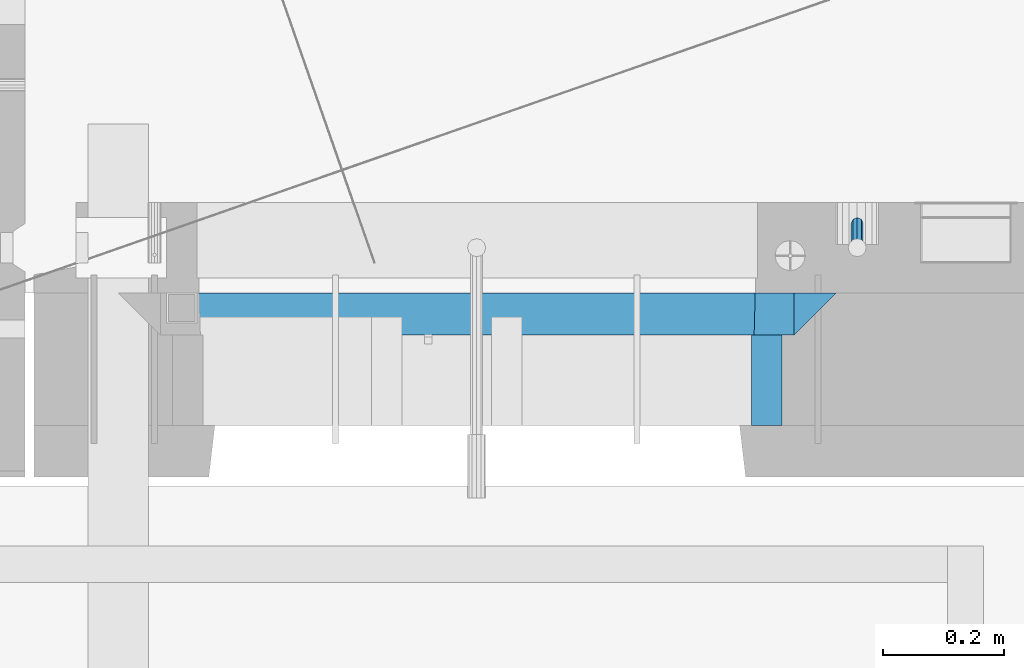
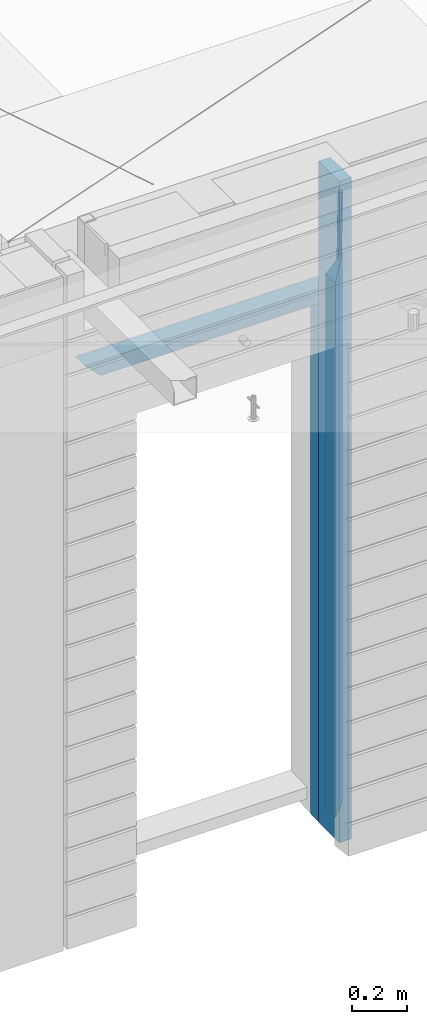
# One storey, part 89 of 341: 5 beams, 1 element without a shape of its own.
"""IFC2X3 building model written with IfcOpenShell, lengths in millimetres."""

import ifcopenshell
import ifcopenshell.guid

model = None  # the IFC model being written
_history = None  # IfcOwnerHistory: only IFC2X3 demands one
_inside = {}  # id of a spatial element -> (the spatial element, [elements in it])
_under = {}  # id of a project, library or spatial element -> (it, [spatial elements below it])
_declared = {}  # id of a project -> (the project, [libraries it declares])
_typed = {}  # id of a type object -> (the type object, [elements of that type])
_made_of = {}  # id of a material, layer set ... -> (it, [elements and type objects made of it])


def new_model(schema):
    """Start an empty IFC model of exactly this schema.

    Asked for "IFC4X3", IfcOpenShell would pick the latest addendum, in which some entities
    have other attributes; the version numbers below select the first issue.
    IFC2X3 requires an IfcOwnerHistory on every rooted entity: one is made here for all.
    """
    global model, _history
    if schema == "IFC4X3":
        model = ifcopenshell.file(schema_version=(4, 3, 0, 0))
    else:
        model = ifcopenshell.file(schema=schema)
    _inside.clear()
    _under.clear()
    _declared.clear()
    _typed.clear()
    _made_of.clear()
    _history = None
    if model.schema == "IFC2X3":
        org = make("IfcOrganization", Name="unknown")
        user = make(
            "IfcPersonAndOrganization",
            ThePerson=make("IfcPerson", FamilyName="unknown"),
            TheOrganization=org,
        )
        app = make(
            "IfcApplication",
            ApplicationDeveloper=org,
            Version="unknown",
            ApplicationFullName="unknown",
            ApplicationIdentifier="unknown",
        )
        _history = make(
            "IfcOwnerHistory",
            OwningUser=user,
            OwningApplication=app,
            ChangeAction="ADDED",
            CreationDate=0,
        )
    return model


def make(cls, **values):
    """One entity of the class cls with the attributes given. An attribute that is None is left unset."""
    return model.create_entity(
        cls, **{name: value for name, value in values.items() if value is not None}
    )


def rooted(cls, **values):
    """An entity with a GlobalId (a new one), such as an element, a storey or a relation."""
    return make(cls, GlobalId=ifcopenshell.guid.new(), OwnerHistory=_history, **values)


def si_unit(unit_type, name, prefix=None):
    """IfcSIUnit, for example si_unit("LENGTHUNIT", "METRE", prefix="MILLI")."""
    return make("IfcSIUnit", UnitType=unit_type, Prefix=prefix, Name=name)


def assignment(units):
    """IfcUnitAssignment: the units of a project."""
    return None if units is None else make("IfcUnitAssignment", Units=units)


def point(xyz):
    """IfcCartesianPoint."""
    return None if xyz is None else make("IfcCartesianPoint", Coordinates=xyz)


def direction(xyz):
    """IfcDirection."""
    return None if xyz is None else make("IfcDirection", DirectionRatios=xyz)


def frame(location, z_axis=None, x_axis=None):
    """IfcAxis2Placement3D, a coordinate frame: its origin and axes. An axis left out is left unset."""
    return make(
        "IfcAxis2Placement3D",
        Location=point(location),
        Axis=direction(z_axis),
        RefDirection=direction(x_axis),
    )


def origin_with_axes():
    """The frame at (0, 0, 0) with the z axis (0, 0, 1) and the x axis (1, 0, 0) written out."""
    return frame((0.0, 0.0, 0.0), z_axis=(0.0, 0.0, 1.0), x_axis=(1.0, 0.0, 0.0))


def place(relative_to, where):
    """IfcLocalPlacement: puts the frame where relative to a parent placement (None: the world)."""
    return make(
        "IfcLocalPlacement", PlacementRelTo=relative_to, RelativePlacement=where
    )


def context(
    kind, dimensions, precision=None, world=None, true_north=None, identifier=None
):
    """IfcGeometricRepresentationContext, for example the 3D "Model" context."""
    return make(
        "IfcGeometricRepresentationContext",
        ContextIdentifier=identifier,
        ContextType=kind,
        CoordinateSpaceDimension=dimensions,
        Precision=precision,
        WorldCoordinateSystem=world,
        TrueNorth=true_north,
    )


def subcontext(parent, identifier, kind, view, scale=None):
    """IfcGeometricRepresentationSubContext, for example "Body" below "Model"."""
    return make(
        "IfcGeometricRepresentationSubContext",
        ContextIdentifier=identifier,
        ContextType=kind,
        ParentContext=parent,
        TargetScale=scale,
        TargetView=view,
    )


def project(units=None, contexts=None):
    """IfcProject with its units and contexts."""
    return rooted(
        "IfcProject",
        Name="project",
        RepresentationContexts=contexts,
        UnitsInContext=assignment(units),
    )


def spatial(cls, under=None, at=None, **own):
    """A site, building, storey or space (cls), placed at a placement, below another one or the project."""
    s = rooted(cls, ObjectPlacement=at, **own)
    if under is not None:
        _under.setdefault(under.id(), (under, []))[1].append(s)
    return s


def faces_of(points, faces, orient=None, outer=None):
    """IfcFace entities. A face is a list of loops; a loop is a list of indices into points, from 0.

    orient and outer hold one flag for each loop. By default every Orientation is true, the
    first loop of a face is its IfcFaceOuterBound and the others are IfcFaceBound.
    """
    made = []
    for i, loops in enumerate(faces):
        bounds = []
        for j, loop in enumerate(loops):
            is_outer = j == 0 if outer is None else outer[i][j]
            bounds.append(
                make(
                    "IfcFaceOuterBound" if is_outer else "IfcFaceBound",
                    Bound=make("IfcPolyLoop", Polygon=[points[k] for k in loop]),
                    Orientation=True if orient is None else orient[i][j],
                )
            )
        made.append(make("IfcFace", Bounds=bounds))
    return made


def faceted_brep(points, faces, orient=None, outer=None, voids=None):
    """IfcFacetedBrep: a solid bounded by flat faces; with voids (closed shells), ...WithVoids."""
    shared = [point(p) for p in points]
    hull = make("IfcClosedShell", CfsFaces=faces_of(shared, faces, orient, outer))
    if voids is None:
        return make("IfcFacetedBrep", Outer=hull)
    return make(
        "IfcFacetedBrepWithVoids",
        Outer=hull,
        Voids=[
            make(cls, CfsFaces=faces_of(shared, fs, o, b)) for cls, fs, o, b in voids
        ],
    )


def shape(context_of_items, identifier, shape_type, items):
    """IfcShapeRepresentation: the items that make up one representation, for example the "Body"."""
    return make(
        "IfcShapeRepresentation",
        ContextOfItems=context_of_items,
        RepresentationIdentifier=identifier,
        RepresentationType=shape_type,
        Items=items,
    )


def material(Name=None, Category=None):
    """IfcMaterial."""
    return make("IfcMaterial", Name=Name, Category=Category)


def made_of(thing, what):
    """Note that an element or type object is made of a material, layer set ...; save() writes the relation."""
    if what is not None:
        _made_of.setdefault(what.id(), (what, []))[1].append(thing)
    return thing


def type_object(cls, material=None, **own):
    """A type object (cls), such as IfcWallType, which elements share."""
    return made_of(rooted(cls, **own), material)


def element(
    cls,
    number,
    at=None,
    inside=None,
    cuts=None,
    type_object=None,
    material=None,
    context=None,
    identifier="Body",
    shape_type=None,
    held_by="IfcProductDefinitionShape",
    body=None,
    shapes=None,
    **own,
):
    """One element of the class cls, such as IfcWall. Its Tag is "e" and its number.

    at: its placement. inside: the storey or other place that contains it. cuts: it is an
    opening in that element (IfcRelVoidsElement). A single representation is given by context,
    identifier, shape_type and body (its items); several are given by shapes. held_by: the class
    of the entity that holds the representations. save() writes the other relations.
    """
    e = rooted(cls, Tag="e%d" % number, ObjectPlacement=at, **own)
    if body is not None:
        shapes = [shape(context, identifier, shape_type, body)]
    if shapes is not None:
        e.Representation = make(held_by, Representations=shapes)
    if inside is not None:
        _inside.setdefault(inside.id(), (inside, []))[1].append(e)
    if cuts is not None:
        rooted(
            "IfcRelVoidsElement", RelatingBuildingElement=cuts, RelatedOpeningElement=e
        )
    if type_object is not None:
        _typed.setdefault(type_object.id(), (type_object, []))[1].append(e)
    return made_of(e, material)


def aggregate(whole, parts):
    """IfcRelAggregates: a whole, such as a stair, and the parts it consists of."""
    return rooted("IfcRelAggregates", RelatingObject=whole, RelatedObjects=parts)


def save(model, path):
    """Write the relations noted so far, then the file.

    IfcRelAggregates (storeys below a building ...), IfcRelContainedInSpatialStructure (elements
    in a storey), IfcRelDefinesByType, IfcRelAssociatesMaterial and IfcRelDeclares: one each for
    every whole, place, type object, material and project.
    """
    for whole, parts in _under.values():
        aggregate(whole, parts)
    for where, things in _inside.values():
        rooted(
            "IfcRelContainedInSpatialStructure",
            RelatedElements=things,
            RelatingStructure=where,
        )
    for kind, things in _typed.values():
        rooted("IfcRelDefinesByType", RelatedObjects=things, RelatingType=kind)
    for what, things in _made_of.values():
        rooted("IfcRelAssociatesMaterial", RelatedObjects=things, RelatingMaterial=what)
    for by, libraries in _declared.values():
        rooted("IfcRelDeclares", RelatingContext=by, RelatedDefinitions=libraries)
    model.write(path)


model = new_model("IFC2X3")

# Units and contexts
model_context = context("Model", 3, precision=1e-05, world=origin_with_axes())
body_context = subcontext(model_context, "Body", "Model", "MODEL_VIEW")
ifc_project = project(units=[si_unit("LENGTHUNIT", "METRE", prefix="MILLI"), si_unit("AREAUNIT", "SQUARE_METRE"), si_unit("VOLUMEUNIT", "CUBIC_METRE"), si_unit("MASSUNIT", "GRAM", prefix="KILO"), si_unit("TIMEUNIT", "SECOND"), si_unit("PLANEANGLEUNIT", "RADIAN"), si_unit("SOLIDANGLEUNIT", "STERADIAN"), si_unit("THERMODYNAMICTEMPERATUREUNIT", "DEGREE_CELSIUS"), si_unit("LUMINOUSINTENSITYUNIT", "LUMEN")], contexts=[model_context])

# Site, building, storey
site_placement = place(None, origin_with_axes())
site = spatial("IfcSite", under=ifc_project, at=site_placement, CompositionType="ELEMENT")
building_placement = place(site_placement, origin_with_axes())
building = spatial("IfcBuilding", under=site, at=building_placement, CompositionType="ELEMENT")
storey_placement = place(building_placement, origin_with_axes())
storey = spatial("IfcBuildingStorey", under=building, at=storey_placement, Name="5", CompositionType="ELEMENT", Elevation=0.0)

# Assembly, beams
assembly_placement = place(storey_placement, origin_with_axes())
assembly = element("IfcElementAssembly", 1, at=assembly_placement, inside=storey, AssemblyPlace="NOTDEFINED", PredefinedType="REINFORCEMENT_UNIT")
ifc_material_1 = material(Name="CONCRETE/C25/30")
beam_type_1 = type_object("IfcBeamType", PredefinedType="NOTDEFINED")
beam_1_placement = place(assembly_placement, frame((8225.00084638596, 10914.9999988604, 96090.0), z_axis=(0.0, 0.0, -1.0), x_axis=(1.0, 0.0, 0.0)))
beam_1 = element("IfcBeam", 2, at=beam_1_placement, type_object=beam_type_1, material=ifc_material_1, Name="SK", context=body_context, shape_type="Brep", body=[
    faceted_brep([(0.0, -35.0, -35.0), (64.051765297294, -34.9999988604341, 29.0540541156515), (65.9436571275874, 34.9999988604341, 30.9459459459467), (0.0, 35.0, -35.0), (1049.99771118164, -34.9999988604341, -35.0), (985.943657065987, -34.9999988604341, 29.0540541156515), (984.051765235694, 34.9999988604341, 30.9459459459467), (1049.99771118164, 34.9999988604341, -35.0)], [[[0, 1, 2, 3]], [[1, 0, 4, 5]], [[2, 1, 5, 6]], [[3, 2, 6, 7]], [[0, 3, 7, 4]], [[6, 5, 4, 7]]]),
])
beam_2_placement = place(assembly_placement, frame((9309.9985575676, 10914.9999977209, 96195.0), z_axis=(-1.0, 3.00000001838171e-08, 0.0), x_axis=(0.0, 0.0, -1.0)))
beam_2 = element("IfcBeam", 3, at=beam_2_placement, type_object=beam_type_1, material=ifc_material_1, Name="SK", context=body_context, shape_type="Brep", body=[
    faceted_brep([(2440.0, -35.0, 35.0), (2440.0, -35.0, -35.0), (2440.0, 35.0, 35.0), (0.0, -35.0, -35.0), (70.0000000000164, 35.0, 35.0), (70.0000000000164, -35.0, 35.0)], [[[0, 1, 2]], [[2, 1, 3, 4]], [[0, 2, 4, 5]], [[1, 0, 5, 3]], [[5, 4, 3]]]),
])
beam_3_placement = place(assembly_placement, frame((9239.9985575676, 10914.9999988604, 96125.0), z_axis=(-1.0, 3.00000001838171e-08, 0.0), x_axis=(0.0, 0.0, -1.0)))
beam_3 = element("IfcBeam", 4, at=beam_3_placement, type_object=beam_type_1, material=ifc_material_1, Name="SK", context=body_context, shape_type="Brep", body=[
    faceted_brep([(2370.0, -34.9999988604341, -35.0), (2370.0, 34.9999988604341, -35.0), (2370.0, 34.9999988604341, 30.9459459459467), (2370.0, -34.9999988604341, 29.0540541156515), (0.0, -35.0, -35.0), (0.0, 35.0, -35.0), (65.9459459459467, 34.9999988604341, 30.9459459459467), (64.0540541156515, -34.9999988604341, 29.0540541156533)], [[[0, 1, 2, 3]], [[4, 5, 1, 0]], [[2, 1, 5, 6]], [[3, 2, 6, 7]], [[0, 3, 7, 4]], [[6, 5, 4, 7]]]),
])
ifc_material_2 = material(Name="TIMBER")
beam_type_2 = type_object("IfcBeamType", Name="50X150", PredefinedType="NOTDEFINED")
beam_4_placement = place(assembly_placement, frame((9229.9985575676, 10804.9999977209, 96690.0), z_axis=(-1.0, 3.00000001838171e-08, 0.0), x_axis=(0.0, 0.0, -1.0)))
beam_4 = element("IfcBeam", 5, at=beam_4_placement, type_object=beam_type_2, material=ifc_material_2, ObjectType="50X150", context=body_context, shape_type="Brep", body=[
    faceted_brep([(0.0, 75.0, -25.0), (1.81898940354586e-12, 75.0, 25.0), (2930.0, 75.0, 25.0), (2930.0, 75.0, -25.0), (1.81898940354586e-12, -75.0000000000009, 25.0), (2930.0, -75.0, 25.0), (0.0, -75.0, -25.0), (2930.0, -75.0, -25.0)], [[[0, 1, 2, 3]], [[1, 4, 5, 2]], [[4, 6, 7, 5]], [[6, 0, 3, 7]], [[5, 7, 3, 2]], [[6, 4, 1, 0]]]),
])
ifc_material_3 = material()
beam_type_3 = type_object("IfcBeamType", Name="D20", PredefinedType="NOTDEFINED")
beam_5_placement = place(assembly_placement, frame((9379.9982799665, 11065.0, 94790.0), z_axis=(0.00020576299992186, -0.999642804629538, -0.0267249099901004), x_axis=(-4.30000201928125e-08, -0.0267249099948059, 0.999642825806181)))
beam_5 = element("IfcBeam", 6, at=beam_5_placement, type_object=beam_type_3, material=ifc_material_3, Name="JM20", ObjectType="D20", context=body_context, shape_type="Brep", body=[
    faceted_brep([(0.0, -10.0, 0.0), (-4.19531716033816e-08, -7.07106781186667, -7.07106781187031), (60.4266690400545, -7.0710677960451, -7.07106780570757), (60.4266690441291, -9.99999998418934, 6.15546014159918e-09), (0.0, 0.0, -10.0), (60.426669036824, 1.58106558956206e-08, -9.99999999384454), (4.196772351861e-08, 7.07106781186303, -7.07106781186667), (60.4266690363438, 7.07106782768096, -7.07106780570757), (0.0, 10.0, 0.0), (60.4266690388904, 10.0000000158179, 6.15182216279209e-09), (4.196772351861e-08, 7.07106781185939, 7.07106781185939), (60.4266690429649, 7.07106782768096, 7.07106781802577), (0.0, 0.0, 10.0), (60.4266690461809, 1.58179318532348e-08, 10.0000000061555), (-4.19531716033816e-08, -7.07106781187031, 7.07106781185939), (60.4266690466611, -7.07106779605238, 7.07106781802213), (61.0378400410118, -7.07106779588503, -7.07106780564936), (60.991799419251, -9.99999998403655, 6.21366780251265e-09), (61.0569027789461, 1.5985278878361e-08, -9.99999999378269), (61.0378209396877, 7.07106782784831, -7.07106780564936), (60.9917724058905, 10.0000000159635, 6.21366780251265e-09), (60.9457317841297, 7.07106782781193, 7.0710678180767), (60.9266690461809, 1.59488990902901e-08, 10.0000000062028), (60.9457508854539, -7.07106779591413, 7.0710678180767), (61.6489592143771, -7.07106614513759, -7.06310863441468), (61.5568818710308, -9.9999984576425, 0.00735959856683621), (61.6870830769039, 1.71821739058942e-06, -9.99179257185824), (61.6489210170112, 7.07106947854481, -7.06310888312146), (61.556827851804, 10.0000015422847, 0.00735924683976918), (61.4647505084577, 7.07106922979438, 7.07782747982128), (61.4266266459163, 1.36643211590126e-06, 10.0065114172685), (61.464788705809, -7.07106639389531, 7.07782772852806), (176.543135720174, -7.07075579406956, -5.56673531796696), (176.451058376813, -9.99968810657447, 1.50373291501455), (176.581259582701, 0.000312069292704109, -8.49541925541052), (176.543097522794, 7.07137982961285, -5.56673556667374), (176.451004357587, 10.00031189336, 1.50373256329476), (176.35892701424, 7.07137958085514, 8.57420079627263), (176.320803151699, 0.000311717507429421, 11.5028847337162), (176.358965211621, -7.07075604281999, 8.57420104497578), (177.098753836006, -7.07075429323595, -5.55949898843028), (176.98362511232, -9.99968666800123, 1.510669025065), (177.146421932586, 0.000313595905026887, -8.48805862247536), (177.098706077581, 7.07138133041735, -5.55949936166144), (176.983557571715, 10.0003133318824, 1.51066849724157), (176.868428848029, 7.07138095712435, 8.58083651073321), (176.820760751449, 0.000313067976094317, 11.5093961447819), (176.868476606425, -7.07075466652896, 8.58083688396073), (177.654312950661, -7.07075204110879, -5.54863964998367), (177.516135294456, -9.99968450931192, 1.52107783331303), (177.711524267797, 0.000315886711177882, -8.47701274570863), (177.654255632195, 7.07138358250813, -5.54864021007961), (177.516054233929, 10.0003154905207, 1.5210770412159), (177.377876577739, 7.0713830223176, 8.59079452451624), (177.320665260588, 0.000315094497636892, 11.5191676202448), (177.377933896176, -7.07075260129932, 8.59079508461218), (299.475681513461, -7.07025820503441, -3.16743615469204), (299.337503857227, -9.99919067323572, 3.9022813287429), (299.532892830684, 0.000809722789199441, -6.09580925047521), (299.475624195184, 7.0718774185807, -3.16743671478434), (299.337422796933, 10.0008093266006, 3.9022805366476), (299.199245140699, 7.07187685839926, 10.9719980200825), (299.142033823475, 0.000808930573839461, 13.9003711158675), (299.199302458976, -7.07025876521584, 10.9719985801767), (300.014932281207, -7.07025601902387, -3.15689559088241), (299.971788958996, -9.99918809853989, 3.91467979818117), (300.032797339853, 0.000811749296190101, -6.08603777550707), (300.014914236686, 7.07187960474585, -3.15689538330298), (299.971753863239, 10.0008119014747, 3.91467990454839), (299.928610539675, 7.07187981509378, 10.9862546943223), (299.910745481058, 0.000812046770079178, 13.9153968789487), (299.92862858421, -7.07025580868321, 10.9862544867447), (300.554271526576, -7.07025682891253, -3.16085443148222), (300.606168552113, -9.999189054608, 3.91002291708173), (300.532783870876, 0.00081099850103783, -6.08970776057868), (300.554292762245, 7.0718787948008, -3.16085451222716), (300.606198583846, 10.0008109453684, 3.9100228028874), (300.658095609382, 7.07187871967653, 10.9809001514495), (300.679583265097, 0.000810892259323737, 13.9097534805496), (300.658074373729, -7.07025690404043, 10.9809002321963), (1493.73308072364, -7.07204854080373, -11.9189871896033), (1493.78497774916, -10.0009807664974, -4.84810984104297), (1493.71159306791, -0.000980713386525167, -14.8478405187034), (1493.7331019593, 7.07008708290959, -11.9189872703519), (1493.7850077809, 9.99901923348079, -4.84810995523549), (1493.83690480642, 7.07008700778533, 2.22276739332847), (1493.85839246215, -0.000980819630058249, 5.15162072242492), (1493.83688357078, -7.07204861592982, 2.22276747407341), (1494.37906755973, -7.07204951083804, -11.9237288414206), (1494.33887067712, -10.0009815982412, -4.85217550811467), (1494.43391396098, -0.000981798046268523, -14.853142475311), (1494.47128160285, 7.07008597443928, -11.9244056328516), (1494.46928102754, 9.99901820595551, -4.85313263573335), (1494.42908414494, 7.07008611855053, 2.2184206975744), (1494.37423774367, -0.000981594239419792, 5.14783433146476), (1494.3368701018, -7.07204936672315, 2.21909748900362), (1495.02495968822, -7.08047207584605, -11.9151326558385), (1494.89268239928, -10.0082034159841, -4.84480482169238), (1495.15612895518, -0.0103996287834889, -14.8435305078528), (1495.20935302251, 7.06046137268277, -11.9145826320491), (1495.15345395346, 9.99009645154365, -4.84402697058613), (1495.02117666451, 7.06236511140742, 2.22630086356003), (1494.89000739757, -0.0077073356587789, 5.15469871557252), (1494.83678333023, -7.07856833711958, 2.22575083976881), (1516.81232084993, -7.36458370639957, -11.6251644217427), (1516.68004356099, -10.292315046534, -4.55483658759658), (1516.94349011689, -0.294511259335195, -14.5535622737552), (1516.99671418422, 6.77634974212924, -11.6246143979515), (1516.94081511517, 9.70598482099194, -4.55405873649033), (1516.80853782622, 6.77825348085389, 2.51626909765582), (1516.67736855928, -0.291818966210485, 5.44466694967014), (1516.62414449194, -7.36267996767492, 2.51571907386642), (1517.44776642873, -7.37287004627251, -11.6167072694061), (1517.34013338278, -10.3009227523598, -4.54605144475318), (1517.52181307798, -0.302052708628253, -14.5458653669793), (1517.51889780765, 6.76954036124152, -11.6176646502499), (1517.44072834359, 9.69946585059188, -4.54740538572696), (1517.33309529764, 6.77141314450637, 2.52325043892597), (1517.2590486484, -0.299404193137889, 5.45240853650103), (1517.26196391872, -7.37099726300949, 2.52420781977162), (1518.08326583009, -7.37099400012448, -11.6084451566603), (1518.00027896308, -10.2989541927, -4.53746177004541), (1518.10018527637, -0.300354896351564, -14.5383632714329), (1518.04112611974, 6.77107862627236, -11.610909819372), (1517.9406844132, 9.70095671561285, -4.54094732948215), (1517.85769754619, 6.77299652303554, 2.53003605713457), (1517.84077809991, -0.297642580735555, 5.45995417190716), (1517.89983725653, -7.36907610336129, 2.53250071984621), (1618.10405127065, -7.07273188347062, -10.3110710264427), (1618.02106440364, -10.0006920760461, -3.24008763982602), (1618.12097071693, -0.00209277969770483, -13.2409891412153), (1618.06191156032, 7.06934074292622, -10.3135356891544), (1617.96146985376, 9.99921883226671, -3.24357319926276), (1617.87848298675, 7.07125863968758, 3.82741018735396), (1617.86156354047, 0.000619535918303882, 6.75732830212473), (1617.92062269709, -7.07081398670744, 3.82987485006379)], [[[0, 1, 2, 3]], [[1, 4, 5, 2]], [[4, 6, 7, 5]], [[6, 8, 9, 7]], [[8, 10, 11, 9]], [[10, 12, 13, 11]], [[12, 14, 15, 13]], [[14, 0, 3, 15]], [[14, 12, 10, 8, 6, 4, 1, 0]], [[3, 2, 16, 17]], [[2, 5, 18, 16]], [[5, 7, 19, 18]], [[7, 9, 20, 19]], [[9, 11, 21, 20]], [[11, 13, 22, 21]], [[13, 15, 23, 22]], [[15, 3, 17, 23]], [[17, 16, 24, 25]], [[16, 18, 26, 24]], [[18, 19, 27, 26]], [[19, 20, 28, 27]], [[20, 21, 29, 28]], [[21, 22, 30, 29]], [[22, 23, 31, 30]], [[23, 17, 25, 31]], [[25, 24, 32, 33]], [[24, 26, 34, 32]], [[26, 27, 35, 34]], [[27, 28, 36, 35]], [[28, 29, 37, 36]], [[29, 30, 38, 37]], [[30, 31, 39, 38]], [[31, 25, 33, 39]], [[33, 32, 40, 41]], [[32, 34, 42, 40]], [[34, 35, 43, 42]], [[35, 36, 44, 43]], [[36, 37, 45, 44]], [[37, 38, 46, 45]], [[38, 39, 47, 46]], [[39, 33, 41, 47]], [[41, 40, 48, 49]], [[40, 42, 50, 48]], [[42, 43, 51, 50]], [[43, 44, 52, 51]], [[44, 45, 53, 52]], [[45, 46, 54, 53]], [[46, 47, 55, 54]], [[47, 41, 49, 55]], [[49, 48, 56, 57]], [[48, 50, 58, 56]], [[50, 51, 59, 58]], [[51, 52, 60, 59]], [[52, 53, 61, 60]], [[53, 54, 62, 61]], [[54, 55, 63, 62]], [[55, 49, 57, 63]], [[57, 56, 64, 65]], [[56, 58, 66, 64]], [[58, 59, 67, 66]], [[59, 60, 68, 67]], [[60, 61, 69, 68]], [[61, 62, 70, 69]], [[62, 63, 71, 70]], [[63, 57, 65, 71]], [[65, 64, 72, 73]], [[64, 66, 74, 72]], [[66, 67, 75, 74]], [[67, 68, 76, 75]], [[68, 69, 77, 76]], [[69, 70, 78, 77]], [[70, 71, 79, 78]], [[71, 65, 73, 79]], [[73, 72, 80, 81]], [[72, 74, 82, 80]], [[74, 75, 83, 82]], [[75, 76, 84, 83]], [[76, 77, 85, 84]], [[77, 78, 86, 85]], [[78, 79, 87, 86]], [[79, 73, 81, 87]], [[81, 80, 88, 89]], [[80, 82, 90, 88]], [[82, 83, 91, 90]], [[83, 84, 92, 91]], [[84, 85, 93, 92]], [[85, 86, 94, 93]], [[86, 87, 95, 94]], [[87, 81, 89, 95]], [[89, 88, 96, 97]], [[88, 90, 98, 96]], [[90, 91, 99, 98]], [[91, 92, 100, 99]], [[92, 93, 101, 100]], [[93, 94, 102, 101]], [[94, 95, 103, 102]], [[95, 89, 97, 103]], [[97, 96, 104, 105]], [[96, 98, 106, 104]], [[98, 99, 107, 106]], [[99, 100, 108, 107]], [[100, 101, 109, 108]], [[101, 102, 110, 109]], [[102, 103, 111, 110]], [[103, 97, 105, 111]], [[105, 104, 112, 113]], [[104, 106, 114, 112]], [[106, 107, 115, 114]], [[107, 108, 116, 115]], [[108, 109, 117, 116]], [[109, 110, 118, 117]], [[110, 111, 119, 118]], [[111, 105, 113, 119]], [[113, 112, 120, 121]], [[112, 114, 122, 120]], [[114, 115, 123, 122]], [[115, 116, 124, 123]], [[116, 117, 125, 124]], [[117, 118, 126, 125]], [[118, 119, 127, 126]], [[119, 113, 121, 127]], [[121, 120, 128, 129]], [[120, 122, 130, 128]], [[122, 123, 131, 130]], [[123, 124, 132, 131]], [[124, 125, 133, 132]], [[125, 126, 134, 133]], [[126, 127, 135, 134]], [[127, 121, 129, 135]], [[130, 131, 132, 133, 134, 135, 129, 128]]]),
])
aggregate(assembly, [beam_5, beam_1, beam_2, beam_3, beam_4])

save(model, "model.ifc")
